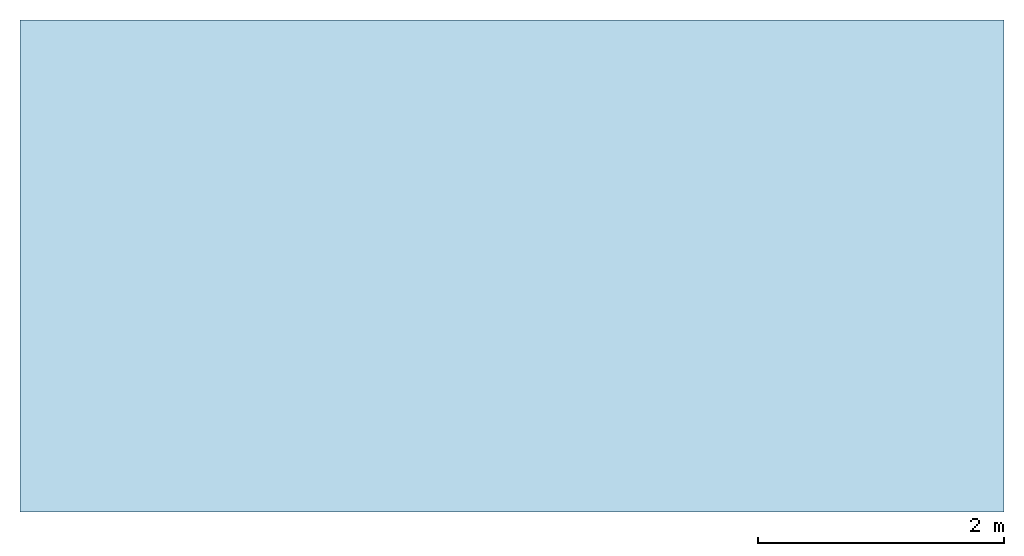
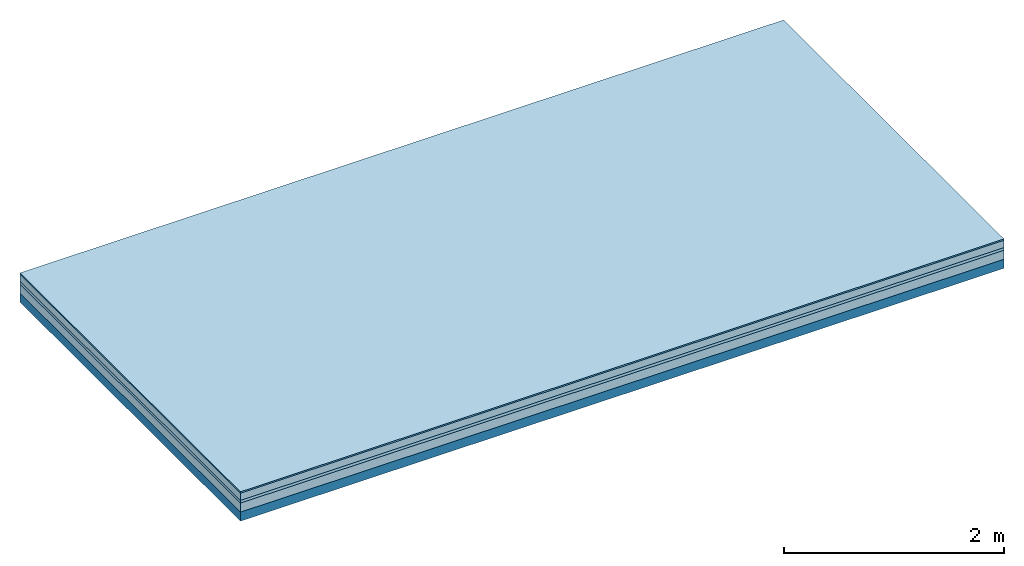
# One storey: 4 plates, 1 member, 1 element without a shape of its own.
"""IFC4 building model written with IfcOpenShell, lengths in metres."""

from ifc_helpers import new_model, si_unit, derived_unit, direction, frame, frame_2d, origin, origin_with_axes, place, context, project, spatial, rectangle, extrude, material, layer, layer_set, type_object, element, aggregate, save


model = new_model("IFC4")

# Units and contexts
plan_context = context("Plan", 3, precision=1e-05, world=origin(), true_north=direction((0.0, 1.0)))
model_context = context("Model", 3, precision=1e-05, world=origin(), true_north=direction((0.0, 1.0)))
ifc_project = project(units=[si_unit("LENGTHUNIT", "METRE"), derived_unit("SOUNDPRESSUREUNIT", [(si_unit("PRESSUREUNIT", "PASCAL", prefix="MICRO"), 0)]), si_unit("ENERGYUNIT", "JOULE", prefix="MEGA"), si_unit("MASSUNIT", "GRAM", prefix="KILO"), derived_unit("THERMALTRANSMITTANCEUNIT", [(si_unit("POWERUNIT", "WATT"), 1), (si_unit("AREAUNIT", "SQUARE_METRE"), -1), (si_unit("THERMODYNAMICTEMPERATUREUNIT", "KELVIN"), -1)]), derived_unit("AREADENSITYUNIT", [(si_unit("MASSUNIT", "GRAM", prefix="KILO"), 1), (si_unit("AREAUNIT", "SQUARE_METRE"), -1)]), derived_unit("USERDEFINED", [(si_unit("ENERGYUNIT", "JOULE", prefix="MEGA"), 1), (si_unit("AREAUNIT", "SQUARE_METRE"), -1)])], contexts=[plan_context, model_context])

# Site, building, storey
site = spatial("IfcSite", under=ifc_project)
building_placement = place(None, origin())
building = spatial("IfcBuilding", under=site, at=building_placement)
storey_placement = place(building_placement, origin())
storey = spatial("IfcBuildingStorey", under=building, at=storey_placement)

# Slab, member, plates
ifc_material_1 = material(Category="11.013")
ifc_layer_1 = layer(ifc_material_1, 0.015, Name="Flooring")
ifc_material_2 = material(Name="Cement screed", Category="04.006")
ifc_layer_2 = layer(ifc_material_2, 0.08, Name="On-material")
ifc_material_3 = material(Name="Wood fiber generic product", Category="10.009")
ifc_layer_3 = layer(ifc_material_3, 0.03, Name="Impact sound insulation")
ifc_material_4 = material(Category="01.002")
ifc_layer_4 = layer(ifc_material_4, 0.1, Name="Sub-floor")
ifc_material_5 = material(Name="Rigid, of the art")
ifc_layer_5 = layer(ifc_material_5, 0.0, Name="Bond")
ifc_layer_6 = layer(None, 0.1, Name="Supporting structure")
ifc_layer_set = layer_set([ifc_layer_1, ifc_layer_2, ifc_layer_3, ifc_layer_4, ifc_layer_5, ifc_layer_6])
slab_type = type_object("IfcSlabType", Name="A2199", PredefinedType="NOTDEFINED", material=ifc_layer_set)
slab_placement = place(None, frame((0.0, 0.0, 0.0), z_axis=(0.0, 0.0, -1.0), x_axis=(1.0, 0.0, 0.0)))
slab = element("IfcSlab", 1, at=slab_placement, inside=storey, type_object=slab_type, material=ifc_layer_set, Name="Slab #1")
ifc_material_6 = material(Name="Solid timber panel")
member_placement = place(slab_placement, origin())
member = element("IfcMember", 2, at=member_placement, material=ifc_material_6, Name="Supporting structure", context=plan_context, shape_type="SweptSolid", body=[
    extrude(rectangle(XDim=1.0, YDim=0.1, at=frame_2d((0.5, 0.05), x_axis=(1.0, 0.0))), frame((0.0, 4.0, 0.225), z_axis=(0.0, -1.0, 0.0), x_axis=(1.0, 0.0, 0.0)), (0.0, 0.0, 1.0), 4.0),
    extrude(rectangle(XDim=1.0, YDim=0.1, at=frame_2d((0.5, 0.05), x_axis=(1.0, 0.0))), frame((1.0, 4.0, 0.225), z_axis=(0.0, -1.0, 0.0), x_axis=(1.0, 0.0, 0.0)), (0.0, 0.0, 1.0), 4.0),
    extrude(rectangle(XDim=1.0, YDim=0.1, at=frame_2d((0.5, 0.05), x_axis=(1.0, 0.0))), frame((2.0, 4.0, 0.225), z_axis=(0.0, -1.0, 0.0), x_axis=(1.0, 0.0, 0.0)), (0.0, 0.0, 1.0), 4.0),
    extrude(rectangle(XDim=1.0, YDim=0.1, at=frame_2d((0.5, 0.05), x_axis=(1.0, 0.0))), frame((3.0, 4.0, 0.225), z_axis=(0.0, -1.0, 0.0), x_axis=(1.0, 0.0, 0.0)), (0.0, 0.0, 1.0), 4.0),
    extrude(rectangle(XDim=1.0, YDim=0.1, at=frame_2d((0.5, 0.05), x_axis=(1.0, 0.0))), frame((4.0, 4.0, 0.225), z_axis=(0.0, -1.0, 0.0), x_axis=(1.0, 0.0, 0.0)), (0.0, 0.0, 1.0), 4.0),
    extrude(rectangle(XDim=1.0, YDim=0.1, at=frame_2d((0.5, 0.05), x_axis=(1.0, 0.0))), frame((5.0, 4.0, 0.225), z_axis=(0.0, -1.0, 0.0), x_axis=(1.0, 0.0, 0.0)), (0.0, 0.0, 1.0), 4.0),
    extrude(rectangle(XDim=1.0, YDim=0.1, at=frame_2d((0.5, 0.05), x_axis=(1.0, 0.0))), frame((6.0, 4.0, 0.225), z_axis=(0.0, -1.0, 0.0), x_axis=(1.0, 0.0, 0.0)), (0.0, 0.0, 1.0), 4.0),
    extrude(rectangle(XDim=1.0, YDim=0.1, at=frame_2d((0.5, 0.05), x_axis=(1.0, 0.0))), frame((7.0, 4.0, 0.225), z_axis=(0.0, -1.0, 0.0), x_axis=(1.0, 0.0, 0.0)), (0.0, 0.0, 1.0), 4.0),
])
plate_1_placement = place(slab_placement, origin())
plate_1 = element("IfcPlate", 3, at=plate_1_placement, material=ifc_material_1, Name="Flooring", context=plan_context, shape_type="SweptSolid", body=[
    extrude(rectangle(XDim=8.0, YDim=4.0, at=frame_2d((4.0, 2.0), x_axis=(1.0, 0.0))), origin_with_axes(), (0.0, 0.0, 1.0), 0.015),
])
plate_2_placement = place(slab_placement, origin())
plate_2 = element("IfcPlate", 4, at=plate_2_placement, material=ifc_material_2, Name="On-material", context=plan_context, shape_type="SweptSolid", body=[
    extrude(rectangle(XDim=8.0, YDim=4.0, at=frame_2d((4.0, 2.0), x_axis=(1.0, 0.0))), frame((0.0, 0.0, 0.015), z_axis=(0.0, 0.0, 1.0), x_axis=(1.0, 0.0, 0.0)), (0.0, 0.0, 1.0), 0.08),
])
plate_3_placement = place(slab_placement, origin())
plate_3 = element("IfcPlate", 5, at=plate_3_placement, material=ifc_material_3, Name="Impact sound insulation", context=plan_context, shape_type="SweptSolid", body=[
    extrude(rectangle(XDim=8.0, YDim=4.0, at=frame_2d((4.0, 2.0), x_axis=(1.0, 0.0))), frame((0.0, 0.0, 0.095), z_axis=(0.0, 0.0, 1.0), x_axis=(1.0, 0.0, 0.0)), (0.0, 0.0, 1.0), 0.03),
])
plate_4_placement = place(slab_placement, origin())
plate_4 = element("IfcPlate", 6, at=plate_4_placement, material=ifc_material_4, Name="Sub-floor", context=plan_context, shape_type="SweptSolid", body=[
    extrude(rectangle(XDim=8.0, YDim=4.0, at=frame_2d((4.0, 2.0), x_axis=(1.0, 0.0))), frame((0.0, 0.0, 0.125), z_axis=(0.0, 0.0, 1.0), x_axis=(1.0, 0.0, 0.0)), (0.0, 0.0, 1.0), 0.1),
])
aggregate(slab, [plate_1, plate_2, plate_3, plate_4, member])

save(model, "model.ifc")
